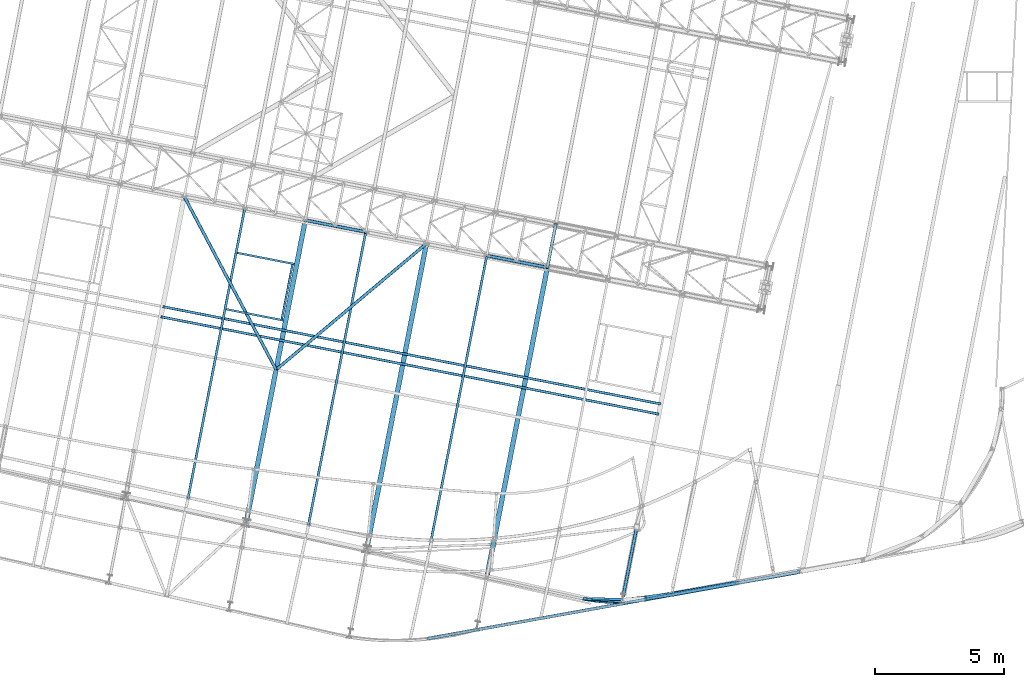
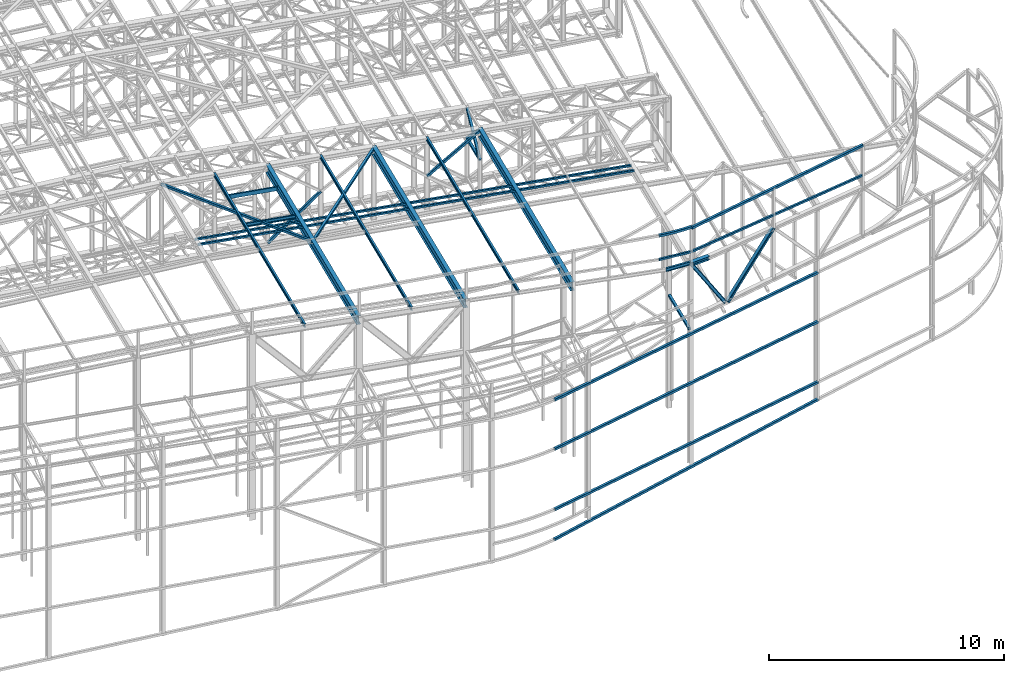
# One storey, part 54 of 215: 25 beams, 6 members, 31 elements without a shape of their own.
"""IFC2X3 building model written with IfcOpenShell, lengths in millimetres."""

from ifc_helpers import new_model, entity, si_unit, frame, origin_with_axes, origin_2d_with_axis, place, context, subcontext, project, spatial, hollow_rectangle, i_section, u_section, extrude, material, type_object, element, aggregate, save


model = new_model("IFC2X3")

# Units and contexts
model_context = context("Model", 3, precision=1e-05, world=origin_with_axes())
body_context = subcontext(model_context, "Body", "Model", "MODEL_VIEW")
ifc_project = project(units=[si_unit("LENGTHUNIT", "METRE", prefix="MILLI"), si_unit("AREAUNIT", "SQUARE_METRE"), si_unit("VOLUMEUNIT", "CUBIC_METRE"), si_unit("MASSUNIT", "GRAM", prefix="KILO"), si_unit("TIMEUNIT", "SECOND"), si_unit("PLANEANGLEUNIT", "RADIAN"), si_unit("SOLIDANGLEUNIT", "STERADIAN"), si_unit("THERMODYNAMICTEMPERATUREUNIT", "DEGREE_CELSIUS"), si_unit("LUMINOUSINTENSITYUNIT", "LUMEN")], contexts=[model_context])

# Site, building, storey
site_placement = place(None, origin_with_axes())
site = spatial("IfcSite", under=ifc_project, at=site_placement, CompositionType="ELEMENT")
building_placement = place(site_placement, origin_with_axes())
building = spatial("IfcBuilding", under=site, at=building_placement, Name="Undefined", CompositionType="ELEMENT")
storey_placement = place(building_placement, origin_with_axes())
storey = spatial("IfcBuildingStorey", under=building, at=storey_placement, Name="Undefined", CompositionType="ELEMENT", Elevation=0.0)

# Assembly, beam
assembly_1_placement = place(storey_placement, origin_with_axes())
assembly_1 = element("IfcElementAssembly", 1, at=assembly_1_placement, inside=storey, Name="Steel Assembly", AssemblyPlace="NOTDEFINED", PredefinedType="RIGID_FRAME")
ifc_material_1 = material(Name="STEEL/S275JR")
beam_type_1 = type_object("IfcBeamType", PredefinedType="NOTDEFINED")
beam_1_placement = place(assembly_1_placement, frame((93496.2583492088, 3339.85287491419, 12587.0336837195), z_axis=(0.0284559839975536, 0.0048888989995797, 0.999583090914059), x_axis=(-0.985149414068134, -0.169254210011706, 0.0288729000019968)))
beam_1 = element("IfcBeam", 2, at=beam_1_placement, type_object=beam_type_1, material=ifc_material_1, Name="LISSE", context=body_context, shape_type="SweptSolid", body=[
    extrude(hollow_rectangle(XDim=100.0, YDim=100.0, WallThickness=4.0, InnerFilletRadius=4.0, OuterFilletRadius=8.0, at=origin_2d_with_axis()), frame((9455.67104534373, 3.53390438061638e-12, -3.67078475617866e-12), z_axis=(-1.0, 0.0, 0.0), x_axis=(-6.93889390390723e-18, -1.0, -3.46944695195361e-18)), (0.0, 0.0, 1.0), 9455.7),
])
aggregate(assembly_1, [beam_1])

assembly_2_placement = place(storey_placement, origin_with_axes())
assembly_2 = element("IfcElementAssembly", 3, at=assembly_2_placement, inside=storey, Name="Steel Assembly", AssemblyPlace="NOTDEFINED", PredefinedType="RIGID_FRAME")
beam_2_placement = place(assembly_2_placement, frame((82641.1518501142, 1854.3765648867, 12907.9578791665), z_axis=(0.03085515999065, 0.000815283999752795, 0.999523533696907), x_axis=(0.996682986251171, -0.0753668800189928, -0.0307059980077377)))
beam_2 = element("IfcBeam", 4, at=beam_2_placement, type_object=beam_type_1, material=ifc_material_1, Name="LISSE", context=body_context, shape_type="SweptSolid", body=[
    extrude(hollow_rectangle(XDim=100.0, YDim=100.0, WallThickness=4.0, InnerFilletRadius=4.0, OuterFilletRadius=8.0, at=origin_2d_with_axis()), frame((1532.71019310848, 9.04114728775676e-13, -1.81367174683815e-12), z_axis=(-1.0, 0.0, 0.0), x_axis=(-6.93889390390723e-18, -1.0, -3.46944695195361e-18)), (0.0, 0.0, 1.0), 1532.7),
])
aggregate(assembly_2, [beam_2])

assembly_3_placement = place(storey_placement, origin_with_axes())
assembly_3 = element("IfcElementAssembly", 5, at=assembly_3_placement, inside=storey, Name="Steel Assembly", AssemblyPlace="NOTDEFINED", PredefinedType="RIGID_FRAME")
beam_type_2 = type_object("IfcBeamType", PredefinedType="NOTDEFINED")
beam_3_placement = place(assembly_3_placement, frame((84141.1088503694, 1715.95527676386, 14159.9969944583), z_axis=(0.0, 0.0, 1.0), x_axis=(-0.996209523870969, 0.0869861169887333, 0.0)))
beam_3 = element("IfcBeam", 6, at=beam_3_placement, type_object=beam_type_2, material=ifc_material_1, Name="LISSE", context=body_context, shape_type="SweptSolid", body=[
    entity("IfcRevolvedAreaSolid", entity("IfcRectangleHollowProfileDef", "AREA", None, entity("IfcAxis2Placement2D", entity("IfcCartesianPoint", [0.0, 0.0]), entity("IfcDirection", [1.0, 0.0])), 120.0, 120.0, 4.0, 4.0, 8.0), entity("IfcAxis2Placement3D", entity("IfcCartesianPoint", [1513.61272523719, 0.0, 0.0]), entity("IfcDirection", [-0.995447097753225, 0.0953156627983118, 0.0]), entity("IfcDirection", [-0.0953156627983118, -0.995447097753225, 0.0])), entity("IfcAxis1Placement", entity("IfcCartesianPoint", [7940.0, 0.0, 0.0]), entity("IfcDirection", [0.0, 1.0, 0.0])), 0.190921162101151),
])
aggregate(assembly_3, [beam_3])

assembly_4_placement = place(storey_placement, origin_with_axes())
assembly_4 = element("IfcElementAssembly", 7, at=assembly_4_placement, inside=storey, Name="Steel Assembly", AssemblyPlace="NOTDEFINED", PredefinedType="RIGID_FRAME")
beam_4_placement = place(assembly_4_placement, frame((93489.2952276447, 3319.07784640978, 14159.9951999002), z_axis=(0.0, 0.0, 1.0), x_axis=(-0.984578083259692, -0.174945700046143, 1.89000000116289e-07)))
beam_4 = element("IfcBeam", 8, at=beam_4_placement, type_object=beam_type_2, material=ifc_material_1, Name="LISSE", context=body_context, shape_type="SweptSolid", body=[
    extrude(hollow_rectangle(XDim=120.0, YDim=120.0, WallThickness=4.0, InnerFilletRadius=4.0, OuterFilletRadius=8.0, at=origin_2d_with_axis()), frame((9516.24312828763, 1.73117514699683e-12, -5.03785716483872e-19), z_axis=(-1.0, 0.0, 0.0), x_axis=(-6.93889390390723e-18, -1.0, -3.46944695195361e-18)), (0.0, 0.0, 1.0), 9516.2),
])
aggregate(assembly_4, [beam_4])

assembly_5_placement = place(storey_placement, origin_with_axes())
assembly_5 = element("IfcElementAssembly", 9, at=assembly_5_placement, inside=storey, Name="Steel Assembly", AssemblyPlace="NOTDEFINED", PredefinedType="RIGID_FRAME")
beam_type_3 = type_object("IfcBeamType", PredefinedType="NOTDEFINED")
beam_5_placement = place(assembly_5_placement, frame((76610.8759726607, 306.829988465469, 2980.96222444186), z_axis=(-0.176457511961093, 0.984308257783004, -1.15189999975954e-05), x_axis=(0.984308257848306, 0.176457511972806, 0.0)))
beam_5 = element("IfcBeam", 10, at=beam_5_placement, type_object=beam_type_3, material=ifc_material_1, Name="LISSE", context=body_context, shape_type="SweptSolid", body=[
    extrude(hollow_rectangle(XDim=120.0, YDim=120.0, WallThickness=5.0, InnerFilletRadius=5.0, OuterFilletRadius=10.0, at=origin_2d_with_axis()), frame((14656.9505710649, 6.20746001998484e-18, -4.06812099869727e-13), z_axis=(-1.0, 0.0, 0.0), x_axis=(-6.93889390390723e-18, -1.0, -3.46944695195361e-18)), (0.0, 0.0, 1.0), 14657.0),
])
aggregate(assembly_5, [beam_5])

assembly_6_placement = place(storey_placement, origin_with_axes())
assembly_6 = element("IfcElementAssembly", 11, at=assembly_6_placement, inside=storey, Name="Steel Assembly", AssemblyPlace="NOTDEFINED", PredefinedType="RIGID_FRAME")
beam_6_placement = place(assembly_6_placement, frame((81261.1503123706, 14685.9029577023, 10796.000000583), z_axis=(0.981422364268518, -0.191859461052493, -0.000300197000082615), x_axis=(0.191859470081235, 0.981422408415534, 0.0)))
beam_6 = element("IfcBeam", 12, at=beam_6_placement, type_object=beam_type_3, material=ifc_material_1, context=body_context, shape_type="SweptSolid", body=[
    extrude(hollow_rectangle(XDim=120.0, YDim=120.0, WallThickness=5.0, InnerFilletRadius=5.0, OuterFilletRadius=10.0, at=origin_2d_with_axis()), frame((1699.99999941724, 1.81898940354586e-12, 0.0), z_axis=(-1.0, 0.0, 0.0), x_axis=(-6.93889390390723e-18, -1.0, -3.46944695195361e-18)), (0.0, 0.0, 1.0), 1700.0),
])
aggregate(assembly_6, [beam_6])

assembly_7_placement = place(storey_placement, origin_with_axes())
assembly_7 = element("IfcElementAssembly", 13, at=assembly_7_placement, inside=storey, Name="Steel Assembly", AssemblyPlace="NOTDEFINED", PredefinedType="RIGID_FRAME")
beam_7_placement = place(assembly_7_placement, frame((84702.7180936971, 4526.35411444231, 8706.00014430118), z_axis=(0.981422409205525, -0.19185946604018, 1.89999991602007e-08), x_axis=(-0.191859508000518, -0.981422401002646, -1.00000033853845e-09)))
beam_7 = element("IfcBeam", 14, at=beam_7_placement, type_object=beam_type_3, material=ifc_material_1, Name="LISSE", context=body_context, shape_type="SweptSolid", body=[
    extrude(hollow_rectangle(XDim=120.0, YDim=120.0, WallThickness=5.0, InnerFilletRadius=5.0, OuterFilletRadius=10.0, at=origin_2d_with_axis()), frame((2638.98586501467, -6.82161857606756e-23, 1.46251618000918e-11), z_axis=(-1.0, 0.0, 0.0), x_axis=(-6.93889390390723e-18, -1.0, -3.46944695195361e-18)), (0.0, 0.0, 1.0), 2639.0),
])
aggregate(assembly_7, [beam_7])

assembly_8_placement = place(storey_placement, origin_with_axes())
assembly_8 = element("IfcElementAssembly", 15, at=assembly_8_placement, inside=storey, Name="Steel Assembly", AssemblyPlace="NOTDEFINED", PredefinedType="RIGID_FRAME")
beam_8_placement = place(assembly_8_placement, frame((76589.8497485344, 307.010131985297, 1423.62744769661), z_axis=(-0.176292317018237, 0.984337858101828, 8.23700000086037e-06), x_axis=(0.983354027459056, 0.176115742082216, 0.0447001350208672)))
beam_8 = element("IfcBeam", 16, at=beam_8_placement, type_object=beam_type_3, material=ifc_material_1, Name="LISSE", context=body_context, shape_type="SweptSolid", body=[
    extrude(hollow_rectangle(XDim=120.0, YDim=120.0, WallThickness=5.0, InnerFilletRadius=5.0, OuterFilletRadius=10.0, at=origin_2d_with_axis()), frame((14691.7134577824, 4.31262157343549e-13, 2.19080718674605e-13), z_axis=(-1.0, 0.0, 0.0), x_axis=(-6.93889390390723e-18, -1.0, -3.46944695195361e-18)), (0.0, 0.0, 1.0), 14691.7),
])
aggregate(assembly_8, [beam_8])

assembly_9_placement = place(storey_placement, origin_with_axes())
assembly_9 = element("IfcElementAssembly", 17, at=assembly_9_placement, inside=storey, Name="Steel Assembly", AssemblyPlace="NOTDEFINED", PredefinedType="RIGID_FRAME")
beam_9_placement = place(assembly_9_placement, frame((76568.9484437469, 15603.1872242184, 12488.7228439144), z_axis=(0.0296817159887862, -0.00507748299807974, 0.999546504622154), x_axis=(-0.76612619210119, -0.642394671084847, 0.0194870300025738)))
beam_9 = element("IfcBeam", 18, at=beam_9_placement, type_object=beam_type_3, material=ifc_material_1, context=body_context, shape_type="SweptSolid", body=[
    extrude(hollow_rectangle(XDim=120.0, YDim=120.0, WallThickness=5.0, InnerFilletRadius=5.0, OuterFilletRadius=10.0, at=origin_2d_with_axis()), frame((7598.53004019939, 9.0415811980654e-13, 3.69070420086631e-12), z_axis=(-1.0, 0.0, 0.0), x_axis=(-6.93889390390723e-18, -1.0, -3.46944695195361e-18)), (0.0, 0.0, 1.0), 7598.5),
])
aggregate(assembly_9, [beam_9])

assembly_10_placement = place(storey_placement, origin_with_axes())
assembly_10 = element("IfcElementAssembly", 19, at=assembly_10_placement, inside=storey, Name="Steel Assembly", AssemblyPlace="NOTDEFINED", PredefinedType="RIGID_FRAME")
beam_10_placement = place(assembly_10_placement, frame((70755.7214186444, 10720.3251038233, 12636.5364293987), z_axis=(0.0294390200131763, -0.00645916600289039, 0.999545708447198), x_axis=(-0.468571448811038, 0.883210188643825, 0.0195079479921331)))
beam_10 = element("IfcBeam", 20, at=beam_10_placement, type_object=beam_type_3, material=ifc_material_1, context=body_context, shape_type="SweptSolid", body=[
    extrude(hollow_rectangle(XDim=120.0, YDim=120.0, WallThickness=5.0, InnerFilletRadius=5.0, OuterFilletRadius=10.0, at=origin_2d_with_axis()), frame((7603.88034545814, 1.41858752529768e-11, 0.0), z_axis=(-1.0, 0.0, 0.0), x_axis=(-6.93889390390723e-18, -1.0, -3.46944695195361e-18)), (0.0, 0.0, 1.0), 7603.9),
])
aggregate(assembly_10, [beam_10])

assembly_11_placement = place(storey_placement, origin_with_axes())
assembly_11 = element("IfcElementAssembly", 21, at=assembly_11_placement, inside=storey, Name="Steel Assembly", AssemblyPlace="NOTDEFINED", PredefinedType="RIGID_FRAME")
beam_11_placement = place(assembly_11_placement, frame((76607.4129320391, 307.651678380859, 6117.50421487743), z_axis=(-0.176457511961093, 0.984308257783004, -1.15189999975954e-05), x_axis=(0.984308257848306, 0.176457511972806, 0.0)))
beam_11 = element("IfcBeam", 22, at=beam_11_placement, type_object=beam_type_3, material=ifc_material_1, Name="LISSE", context=body_context, shape_type="SweptSolid", body=[
    extrude(hollow_rectangle(XDim=120.0, YDim=120.0, WallThickness=5.0, InnerFilletRadius=5.0, OuterFilletRadius=10.0, at=origin_2d_with_axis()), frame((14656.9505710649, 6.20746001998484e-18, -4.06812099869727e-13), z_axis=(-1.0, 0.0, 0.0), x_axis=(-6.93889390390723e-18, -1.0, -3.46944695195361e-18)), (0.0, 0.0, 1.0), 14657.0),
])
aggregate(assembly_11, [beam_11])

assembly_12_placement = place(storey_placement, origin_with_axes())
assembly_12 = element("IfcElementAssembly", 23, at=assembly_12_placement, inside=storey, Name="Steel Assembly", AssemblyPlace="NOTDEFINED", PredefinedType="RIGID_FRAME")
beam_12_placement = place(assembly_12_placement, frame((76607.4129320332, 307.651678374932, 8675.00421487745), z_axis=(-0.176457511961093, 0.984308257783004, -1.15189999975954e-05), x_axis=(0.984308257848306, 0.176457511972806, 0.0)))
beam_12 = element("IfcBeam", 24, at=beam_12_placement, type_object=beam_type_3, material=ifc_material_1, Name="LISSE", context=body_context, shape_type="SweptSolid", body=[
    extrude(hollow_rectangle(XDim=120.0, YDim=120.0, WallThickness=5.0, InnerFilletRadius=5.0, OuterFilletRadius=10.0, at=origin_2d_with_axis()), frame((14656.9505710649, 6.20746001998484e-18, -4.06812099869727e-13), z_axis=(-1.0, 0.0, 0.0), x_axis=(-6.93889390390723e-18, -1.0, -3.46944695195361e-18)), (0.0, 0.0, 1.0), 14657.0),
])
aggregate(assembly_12, [beam_12])

assembly_13_placement = place(storey_placement, origin_with_axes())
assembly_13 = element("IfcElementAssembly", 25, at=assembly_13_placement, inside=storey, Name="Steel Assembly", AssemblyPlace="NOTDEFINED", PredefinedType="RIGID_FRAME")
beam_type_4 = type_object("IfcBeamType", PredefinedType="NOTDEFINED")
beam_13_placement = place(assembly_13_placement, frame((66364.7622297451, 13168.7168552192, 12789.6963510518), z_axis=(-0.0304080339975108, 0.00594450399951394, -0.999519891918418), x_axis=(0.980943076639626, -0.191809005929534, -0.0309836349886174)))
beam_13 = element("IfcBeam", 26, at=beam_13_placement, type_object=beam_type_4, material=ifc_material_1, context=body_context, shape_type="SweptSolid", body=[
    extrude(hollow_rectangle(XDim=100.0, YDim=100.0, WallThickness=5.0, InnerFilletRadius=5.0, OuterFilletRadius=10.0, at=origin_2d_with_axis()), frame((19666.2260350888, 7.85512124139754e-13, 1.81898940354586e-12), z_axis=(-1.0, 0.0, 0.0), x_axis=(-6.93889390390723e-18, -1.0, -3.46944695195361e-18)), (0.0, 0.0, 1.0), 19666.2),
])
aggregate(assembly_13, [beam_13])

assembly_14_placement = place(storey_placement, origin_with_axes())
assembly_14 = element("IfcElementAssembly", 27, at=assembly_14_placement, inside=storey, Name="Steel Assembly", AssemblyPlace="NOTDEFINED", PredefinedType="RIGID_FRAME")
beam_14_placement = place(assembly_14_placement, frame((66287.5080350144, 12776.2476940306, 12789.6963521669), z_axis=(-0.0304080339975108, 0.00594450399951394, -0.999519891918418), x_axis=(0.980943076639626, -0.191809005929534, -0.0309836349886174)))
beam_14 = element("IfcBeam", 28, at=beam_14_placement, type_object=beam_type_4, material=ifc_material_1, context=body_context, shape_type="SweptSolid", body=[
    extrude(hollow_rectangle(XDim=100.0, YDim=100.0, WallThickness=5.0, InnerFilletRadius=5.0, OuterFilletRadius=10.0, at=origin_2d_with_axis()), frame((19666.7288325615, 1.47390537647347e-11, -6.82326724030288e-14), z_axis=(-1.0, 0.0, 0.0), x_axis=(-6.93889390390723e-18, -1.0, -3.46944695195361e-18)), (0.0, 0.0, 1.0), 19666.7),
])
aggregate(assembly_14, [beam_14])

assembly_15_placement = place(storey_placement, origin_with_axes())
assembly_15 = element("IfcElementAssembly", 29, at=assembly_15_placement, inside=storey, Name="Steel Assembly", AssemblyPlace="NOTDEFINED", PredefinedType="RIGID_FRAME")
beam_type_5 = type_object("IfcBeamType", Name="IPE180", PredefinedType="NOTDEFINED")
beam_15_placement = place(assembly_15_placement, frame((76602.4400566349, 3318.44735560647, 12459.6637931695), z_axis=(0.0304080349965938, -0.00594450399933318, 0.999519891888024), x_axis=(0.191859470081235, 0.981422408415534, 0.0)))
beam_15 = element("IfcBeam", 30, at=beam_15_placement, type_object=beam_type_5, material=ifc_material_1, ObjectType="IPE180", context=body_context, shape_type="SweptSolid", body=[
    extrude(i_section(OverallWidth=91.0, OverallDepth=180.0, WebThickness=5.300000191, FlangeThickness=8.0, FilletRadius=9.0, at=origin_2d_with_axis()), frame((12050.092871084, -1.45519152283669e-11, -1.81898940354586e-12), z_axis=(-1.0, 0.0, 0.0), x_axis=(-6.93889390390723e-18, -1.0, -3.46944695195361e-18)), (0.0, 0.0, 1.0), 12050.1),
])
aggregate(assembly_15, [beam_15])

assembly_16_placement = place(storey_placement, origin_with_axes())
assembly_16 = element("IfcElementAssembly", 31, at=assembly_16_placement, inside=storey, Name="Steel Assembly", AssemblyPlace="NOTDEFINED", PredefinedType="RIGID_FRAME")
beam_16_placement = place(assembly_16_placement, frame((84172.1607575759, 1826.54996482621, 12220.5433041363), z_axis=(0.0302564720050506, -0.00664840000111122, 0.999520057167055), x_axis=(-0.999173117188295, 0.0269699680050824, 0.0304253630057332)))
beam_16 = element("IfcBeam", 32, at=beam_16_placement, type_object=beam_type_5, material=ifc_material_1, Name="POUTRE", ObjectType="IPE180", context=body_context, shape_type="SweptSolid", body=[
    extrude(i_section(OverallWidth=91.0, OverallDepth=180.0, WebThickness=5.300000191, FlangeThickness=8.0, FilletRadius=9.0, at=origin_2d_with_axis()), frame((1180.65041338662, 9.09750714521556e-13, 0.0), z_axis=(-1.0, 0.0, 0.0), x_axis=(-6.93889390390723e-18, -1.0, -3.46944695195361e-18)), (0.0, 0.0, 1.0), 1180.7),
])
aggregate(assembly_16, [beam_16])

assembly_17_placement = place(storey_placement, origin_with_axes())
assembly_17 = element("IfcElementAssembly", 33, at=assembly_17_placement, inside=storey, Name="Steel Assembly", AssemblyPlace="NOTDEFINED", PredefinedType="RIGID_FRAME")
beam_17_placement = place(assembly_17_placement, frame((67257.8844808792, 5313.22993242025, 12755.8135324581), z_axis=(0.0304080349965938, -0.00594450399933318, 0.999519891888024), x_axis=(0.191859470081235, 0.981422408415534, 0.0)))
beam_17 = element("IfcBeam", 34, at=beam_17_placement, type_object=beam_type_5, material=ifc_material_1, ObjectType="IPE180", context=body_context, shape_type="SweptSolid", body=[
    extrude(i_section(OverallWidth=91.0, OverallDepth=180.0, WebThickness=5.300000191, FlangeThickness=8.0, FilletRadius=9.0, at=origin_2d_with_axis()), frame((11885.2100984513, 0.0, -1.81898940354586e-12), z_axis=(-1.0, 0.0, 0.0), x_axis=(-6.93889390390723e-18, -1.0, -3.46944695195361e-18)), (0.0, 0.0, 1.0), 11885.2),
])
aggregate(assembly_17, [beam_17])

assembly_18_placement = place(storey_placement, origin_with_axes())
assembly_18 = element("IfcElementAssembly", 35, at=assembly_18_placement, inside=storey, Name="Steel Assembly", AssemblyPlace="NOTDEFINED", PredefinedType="RIGID_FRAME")
beam_18_placement = place(assembly_18_placement, frame((71930.4692510312, 4317.41313373718, 12607.7386880589), z_axis=(0.0304080349965938, -0.00594450399933318, 0.999519891888024), x_axis=(0.191859470081235, 0.981422408415534, 0.0)))
beam_18 = element("IfcBeam", 36, at=beam_18_placement, type_object=beam_type_5, material=ifc_material_1, ObjectType="IPE180", context=body_context, shape_type="SweptSolid", body=[
    extrude(i_section(OverallWidth=91.0, OverallDepth=180.0, WebThickness=5.300000191, FlangeThickness=8.0, FilletRadius=9.0, at=origin_2d_with_axis()), frame((11966.0473477474, 0.0, 1.81898940354586e-12), z_axis=(-1.0, 0.0, 0.0), x_axis=(-6.93889390390723e-18, -1.0, -3.46944695195361e-18)), (0.0, 0.0, 1.0), 11966.0),
])
aggregate(assembly_18, [beam_18])

assembly_19_placement = place(storey_placement, origin_with_axes())
assembly_19 = element("IfcElementAssembly", 37, at=assembly_19_placement, inside=storey, Name="Steel Assembly", AssemblyPlace="NOTDEFINED", PredefinedType="RIGID_FRAME")
beam_type_6 = type_object("IfcBeamType", Name="HEA200", PredefinedType="NOTDEFINED")
beam_19_placement = place(assembly_19_placement, frame((84135.1801459227, 1777.34958853918, 12214.8382399268), z_axis=(0.0290707219875938, 0.00432404399815404, 0.999568004573287), x_axis=(0.996472900475069, 0.0786259960374849, -0.0293208350139779)))
beam_19 = element("IfcBeam", 38, at=beam_19_placement, type_object=beam_type_6, material=ifc_material_1, Name="LISSE", ObjectType="HEA200", context=body_context, shape_type="SweptSolid", body=[
    extrude(i_section(OverallWidth=200.0, OverallDepth=190.0, WebThickness=6.5, FlangeThickness=10.0, FilletRadius=18.0, at=origin_2d_with_axis()), frame((947.32691570714, -6.57982029728301e-15, -1.81898940354586e-12), z_axis=(-1.0, 0.0, 0.0), x_axis=(-6.93889390390723e-18, -1.0, -3.46944695195361e-18)), (0.0, 0.0, 1.0), 947.3),
])
aggregate(assembly_19, [beam_19])

assembly_20_placement = place(storey_placement, origin_with_axes())
assembly_20 = element("IfcElementAssembly", 39, at=assembly_20_placement, inside=storey, Name="Steel Assembly", AssemblyPlace="NOTDEFINED", PredefinedType="RIGID_FRAME")
ifc_material_2 = material(Name="STEEL/S235JR")
beam_type_7 = type_object("IfcBeamType", Name="UPN200", PredefinedType="NOTDEFINED")
beam_20_placement = place(assembly_20_placement, frame((70973.0147696595, 12685.7746862869, 12676.6170854166), z_axis=(0.0304080349965938, -0.00594450399933318, 0.999519891888024), x_axis=(0.191859470081235, 0.981422408415534, 0.0)))
beam_20 = element("IfcBeam", 40, at=beam_20_placement, type_object=beam_type_7, material=ifc_material_2, ObjectType="UPN200", context=body_context, shape_type="SweptSolid", body=[
    extrude(u_section(Depth=200.0, FlangeWidth=75.0, WebThickness=8.5, FlangeThickness=11.5, FilletRadius=11.5, EdgeRadius=6.0, FlangeSlope=0.0798299857122373, at=origin_2d_with_axis()), frame((2149.96645748991, 6.98418044224936e-15, -1.81533901666633e-12), z_axis=(-1.0, 0.0, 0.0), x_axis=(-6.93889390390723e-18, -1.0, -3.46944695195361e-18)), (0.0, 0.0, 1.0), 2150.0),
])
aggregate(assembly_20, [beam_20])

assembly_21_placement = place(storey_placement, origin_with_axes())
assembly_21 = element("IfcElementAssembly", 41, at=assembly_21_placement, inside=storey, Name="Steel Assembly", AssemblyPlace="NOTDEFINED", PredefinedType="RIGID_FRAME")
beam_21_placement = place(assembly_21_placement, frame((71453.3111163364, 14820.7534542245, 12674.7027104274), z_axis=(0.0304080349965938, -0.00594450399933318, 0.999519891888024), x_axis=(-0.980947274706054, 0.19178753394253, 0.030983641990716)))
beam_21 = element("IfcBeam", 42, at=beam_21_placement, type_object=beam_type_7, material=ifc_material_2, ObjectType="UPN200", context=body_context, shape_type="SweptSolid", body=[
    extrude(u_section(Depth=200.0, FlangeWidth=75.0, WebThickness=8.5, FlangeThickness=11.5, FilletRadius=11.5, EdgeRadius=6.0, FlangeSlope=0.0798299857122373, at=origin_2d_with_axis()), frame((2249.04686463703, -3.60705473231594e-12, 7.80294878931578e-15), z_axis=(-1.0, 0.0, 0.0), x_axis=(-6.93889390390723e-18, -1.0, -3.46944695195361e-18)), (0.0, 0.0, 1.0), 2249.0),
])
aggregate(assembly_21, [beam_21])

assembly_22_placement = place(storey_placement, origin_with_axes())
assembly_22 = element("IfcElementAssembly", 43, at=assembly_22_placement, inside=storey, Name="Steel Assembly", AssemblyPlace="NOTDEFINED", PredefinedType="RIGID_FRAME")
beam_22_placement = place(assembly_22_placement, frame((68820.1791296207, 13068.4316015984, 12744.3863730355), z_axis=(0.0304080349965938, -0.00594450399933318, 0.999519891888024), x_axis=(0.980947274706054, -0.191787533942531, -0.0309836419907153)))
beam_22 = element("IfcBeam", 44, at=beam_22_placement, type_object=beam_type_7, material=ifc_material_2, ObjectType="UPN200", context=body_context, shape_type="SweptSolid", body=[
    extrude(u_section(Depth=200.0, FlangeWidth=75.0, WebThickness=8.5, FlangeThickness=11.5, FilletRadius=11.5, EdgeRadius=6.0, FlangeSlope=0.0798299857122373, at=origin_2d_with_axis()), frame((2249.04686463703, -3.60705473231594e-12, 7.80294878931578e-15), z_axis=(-1.0, 0.0, 0.0), x_axis=(-6.93889390390723e-18, -1.0, -3.46944695195361e-18)), (0.0, 0.0, 1.0), 2249.0),
])
aggregate(assembly_22, [beam_22])

# Assembly, member
assembly_23_placement = place(storey_placement, origin_with_axes())
assembly_23 = element("IfcElementAssembly", 45, at=assembly_23_placement, inside=storey, Name="Steel Assembly", AssemblyPlace="NOTDEFINED", PredefinedType="RIGID_FRAME")
member_type_1 = type_object("IfcMemberType", PredefinedType="NOTDEFINED")
member_1_placement = place(assembly_23_placement, frame((81587.3114106358, 16354.3210515458, 10796.0000007861), z_axis=(0.981461701624211, -0.19165823792662, 0.000219270999915979), x_axis=(-0.140138869039808, -0.716855033203644, 0.682993381194025)))
member_1 = element("IfcMember", 46, at=member_1_placement, type_object=member_type_1, material=ifc_material_1, context=body_context, shape_type="SweptSolid", body=[
    extrude(hollow_rectangle(XDim=120.0, YDim=120.0, WallThickness=5.0, InnerFilletRadius=5.0, OuterFilletRadius=10.0, at=origin_2d_with_axis()), frame((2327.41350452431, -7.27595761418343e-12, -1.06739260704213e-13), z_axis=(-1.0, 0.0, 0.0), x_axis=(-6.93889390390723e-18, -1.0, -3.46944695195361e-18)), (0.0, 0.0, 1.0), 2327.4),
])
aggregate(assembly_23, [member_1])

assembly_24_placement = place(storey_placement, origin_with_axes())
assembly_24 = element("IfcElementAssembly", 47, at=assembly_24_placement, inside=storey, Name="Steel Assembly", AssemblyPlace="NOTDEFINED", PredefinedType="RIGID_FRAME")
member_2_placement = place(assembly_24_placement, frame((81261.1503123706, 14685.9029577023, 10796.000000583), z_axis=(0.981461701624211, -0.19165823792662, -0.000219270999915979), x_axis=(0.140138870001192, 0.716855037006089, 0.682993377005801)))
member_2 = element("IfcMember", 48, at=member_2_placement, type_object=member_type_1, material=ifc_material_1, context=body_context, shape_type="SweptSolid", body=[
    extrude(hollow_rectangle(XDim=120.0, YDim=120.0, WallThickness=5.0, InnerFilletRadius=5.0, OuterFilletRadius=10.0, at=origin_2d_with_axis()), frame((2327.41350452431, -7.27595761418343e-12, -1.06739260704213e-13), z_axis=(-1.0, 0.0, 0.0), x_axis=(-6.93889390390723e-18, -1.0, -3.46944695195361e-18)), (0.0, 0.0, 1.0), 2327.4),
])
aggregate(assembly_24, [member_2])

assembly_25_placement = place(storey_placement, origin_with_axes())
assembly_25 = element("IfcElementAssembly", 49, at=assembly_25_placement, inside=storey, Name="Steel Assembly", AssemblyPlace="NOTDEFINED", PredefinedType="RIGID_FRAME")
member_3_placement = place(assembly_25_placement, frame((78917.1014017216, 15144.1439327369, 10489.6726248693), z_axis=(0.597857237183729, -0.116875832035918, -0.793036420243705), x_axis=(0.778303714010845, -0.15215154400212, 0.609174225008491)))
member_3 = element("IfcMember", 50, at=member_3_placement, type_object=member_type_1, material=ifc_material_1, context=body_context, shape_type="SweptSolid", body=[
    extrude(hollow_rectangle(XDim=120.0, YDim=120.0, WallThickness=5.0, InnerFilletRadius=5.0, OuterFilletRadius=10.0, at=origin_2d_with_axis()), frame((3005.68349365877, -3.45147056449385e-14, 7.44280656515321e-12), z_axis=(-1.0, 0.0, 0.0), x_axis=(-6.93889390390723e-18, -1.0, -3.46944695195361e-18)), (0.0, 0.0, 1.0), 3005.7),
])
aggregate(assembly_25, [member_3])

assembly_26_placement = place(storey_placement, origin_with_axes())
assembly_26 = element("IfcElementAssembly", 51, at=assembly_26_placement, inside=storey, Name="Steel Assembly", AssemblyPlace="NOTDEFINED", PredefinedType="RIGID_FRAME")
member_4_placement = place(assembly_26_placement, frame((71889.6710264849, 16517.9448846367, 8654.99756487869), z_axis=(0.655817009937109, -0.128206468987706, -0.743953728928658), x_axis=(0.730132860802437, -0.142734564961378, 0.668231134819185)))
member_4 = element("IfcMember", 52, at=member_4_placement, type_object=member_type_1, material=ifc_material_1, context=body_context, shape_type="SweptSolid", body=[
    extrude(hollow_rectangle(XDim=120.0, YDim=120.0, WallThickness=5.0, InnerFilletRadius=5.0, OuterFilletRadius=10.0, at=origin_2d_with_axis()), frame((3203.9848555289, -6.00376509824008e-14, -1.77856887857925e-13), z_axis=(-1.0, 0.0, 0.0), x_axis=(-6.93889390390723e-18, -1.0, -3.46944695195361e-18)), (0.0, 0.0, 1.0), 3204.0),
])
aggregate(assembly_26, [member_4])

assembly_27_placement = place(storey_placement, origin_with_axes())
assembly_27 = element("IfcElementAssembly", 53, at=assembly_27_placement, inside=storey, Name="Steel Assembly", AssemblyPlace="NOTDEFINED", PredefinedType="RIGID_FRAME")
member_type_2 = type_object("IfcMemberType", Name="HEA160", PredefinedType="NOTDEFINED")
member_5_placement = place(assembly_27_placement, frame((84165.8280684174, 1780.22229466291, 12219.9995940732), z_axis=(0.82960010354475, 0.104146931942849, 0.548559098698975), x_axis=(0.544279951897565, 0.0683843589871301, -0.836111782842644)))
member_5 = element("IfcMember", 54, at=member_5_placement, type_object=member_type_2, material=ifc_material_1, Name="LISSE", ObjectType="HEA160", context=body_context, shape_type="SweptSolid", body=[
    extrude(i_section(OverallWidth=160.0, OverallDepth=152.0, WebThickness=6.0, FlangeThickness=9.0, FilletRadius=15.0, at=origin_2d_with_axis()), frame((3359.42495049695, 3.11188649944082e-14, 0.0), z_axis=(-1.0, 0.0, 0.0), x_axis=(-6.93889390390723e-18, -1.0, -3.46944695195361e-18)), (0.0, 0.0, 1.0), 3359.4),
])
aggregate(assembly_27, [member_5])

assembly_28_placement = place(storey_placement, origin_with_axes())
assembly_28 = element("IfcElementAssembly", 55, at=assembly_28_placement, inside=storey, Name="Steel Assembly", AssemblyPlace="NOTDEFINED", PredefinedType="RIGID_FRAME")
member_6_placement = place(assembly_28_placement, frame((88610.7550906237, 2469.67453829404, 12111.711211169), z_axis=(-0.713898209749785, -0.128045605955121, 0.688442930758707), x_axis=(-0.677629451027263, -0.12154010000489, -0.725290515029179)))
member_6 = element("IfcMember", 56, at=member_6_placement, type_object=member_type_2, material=ifc_material_1, Name="LISSE", ObjectType="HEA160", context=body_context, shape_type="SweptSolid", body=[
    extrude(i_section(OverallWidth=160.0, OverallDepth=152.0, WebThickness=6.0, FlangeThickness=9.0, FilletRadius=15.0, at=origin_2d_with_axis()), frame((3727.08064981423, -1.72645179963577e-12, 0.0), z_axis=(-1.0, 0.0, 0.0), x_axis=(-6.93889390390723e-18, -1.0, -3.46944695195361e-18)), (0.0, 0.0, 1.0), 3727.1),
])
aggregate(assembly_28, [member_6])

# Assembly, beam
assembly_29_placement = place(storey_placement, origin_with_axes())
assembly_29 = element("IfcElementAssembly", 57, at=assembly_29_placement, inside=storey, Name="Steel Assembly", AssemblyPlace="NOTDEFINED", PredefinedType="RIGID_FRAME")
beam_type_8 = type_object("IfcBeamType", Name="IPE450", PredefinedType="NOTDEFINED")
beam_23_placement = place(assembly_29_placement, frame((81261.1517411964, 14685.8989568608, 12248.4906423921), z_axis=(0.0, 0.0, 1.0), x_axis=(-0.191859508000518, -0.981422401002646, -1.00000033853845e-09)))
beam_23 = element("IfcBeam", 58, at=beam_23_placement, type_object=beam_type_8, material=ifc_material_1, Name="POUTRE", ObjectType="IPE450", context=body_context, shape_type="SweptSolid", body=[
    extrude(i_section(OverallWidth=190.0, OverallDepth=450.0, WebThickness=9.399999619, FlangeThickness=14.60000038, FilletRadius=21.0, at=origin_2d_with_axis()), frame((12131.7394647691, 2.32758935032745e-15, 0.0), z_axis=(-1.0, 0.0, 0.0), x_axis=(-6.93889390390723e-18, -1.0, -3.46944695195361e-18)), (0.0, 0.0, 1.0), 12131.7),
])
aggregate(assembly_29, [beam_23])

assembly_30_placement = place(storey_placement, origin_with_axes())
assembly_30 = element("IfcElementAssembly", 59, at=assembly_30_placement, inside=storey, Name="Steel Assembly", AssemblyPlace="NOTDEFINED", PredefinedType="RIGID_FRAME")
beam_24_placement = place(assembly_30_placement, frame((76573.0559826015, 15602.3804532917, 12396.5655406805), z_axis=(0.0, 0.0, 1.0), x_axis=(-0.191859508000518, -0.981422401002646, -1.00000033853845e-09)))
beam_24 = element("IfcBeam", 60, at=beam_24_placement, type_object=beam_type_8, material=ifc_material_1, Name="POUTRE", ObjectType="IPE450", context=body_context, shape_type="SweptSolid", body=[
    extrude(i_section(OverallWidth=190.0, OverallDepth=450.0, WebThickness=9.399999619, FlangeThickness=14.60000038, FilletRadius=21.0, at=origin_2d_with_axis()), frame((12050.8159918558, 2.31206346560256e-15, 3.63797881207581e-12), z_axis=(-1.0, 0.0, 0.0), x_axis=(-6.93889390390723e-18, -1.0, -3.46944695195361e-18)), (0.0, 0.0, 1.0), 12050.8),
])
aggregate(assembly_30, [beam_24])

assembly_31_placement = place(storey_placement, origin_with_axes())
assembly_31 = element("IfcElementAssembly", 61, at=assembly_31_placement, inside=storey, Name="Steel Assembly", AssemblyPlace="NOTDEFINED", PredefinedType="RIGID_FRAME")
beam_25_placement = place(assembly_31_placement, frame((71884.9676440914, 16518.8999063792, 12544.6404423314), z_axis=(-3.29780000104066e-05, -0.00016869500003863, 0.999999985227224), x_axis=(-0.191859431000601, -0.981422401003075, -0.00017188800000052)))
beam_25 = element("IfcBeam", 62, at=beam_25_placement, type_object=beam_type_8, material=ifc_material_1, Name="POUTRE", ObjectType="IPE450", context=body_context, shape_type="SweptSolid", body=[
    extrude(i_section(OverallWidth=190.0, OverallDepth=450.0, WebThickness=9.399999619, FlangeThickness=14.60000038, FilletRadius=21.0, at=origin_2d_with_axis()), frame((11941.6877117739, -4.34593345437408e-13, 0.0), z_axis=(-1.0, 0.0, 0.0), x_axis=(-6.93889390390723e-18, -1.0, -3.46944695195361e-18)), (0.0, 0.0, 1.0), 11941.7),
])
aggregate(assembly_31, [beam_25])

save(model, "model.ifc")
